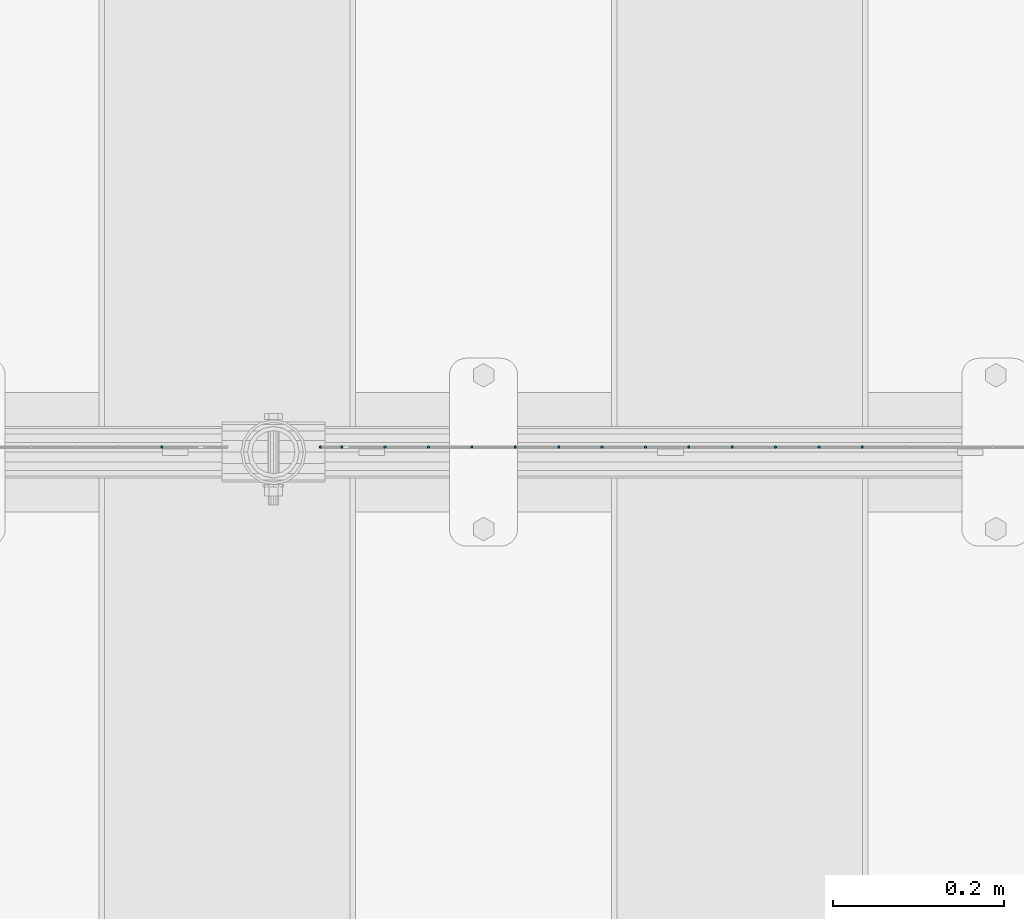
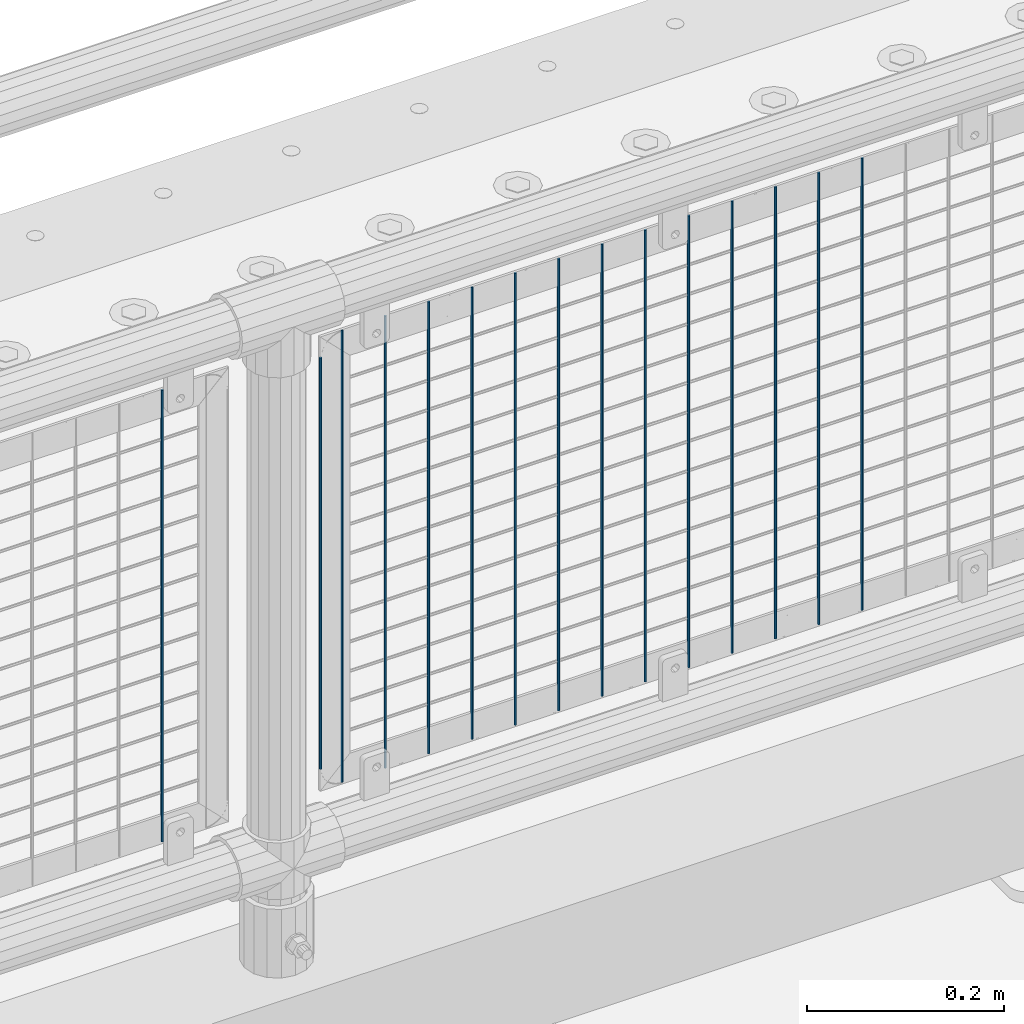
# One storey, part 71 of 270: 15 columns.
"""IFC2X3 building model written with IfcOpenShell, lengths in millimetres."""

import ifcopenshell
import ifcopenshell.guid

model = None  # the IFC model being written
_history = None  # IfcOwnerHistory: only IFC2X3 demands one
_inside = {}  # id of a spatial element -> (the spatial element, [elements in it])
_under = {}  # id of a project, library or spatial element -> (it, [spatial elements below it])
_declared = {}  # id of a project -> (the project, [libraries it declares])
_typed = {}  # id of a type object -> (the type object, [elements of that type])
_made_of = {}  # id of a material, layer set ... -> (it, [elements and type objects made of it])


def new_model(schema):
    """Start an empty IFC model of exactly this schema.

    Asked for "IFC4X3", IfcOpenShell would pick the latest addendum, in which some entities
    have other attributes; the version numbers below select the first issue.
    IFC2X3 requires an IfcOwnerHistory on every rooted entity: one is made here for all.
    """
    global model, _history
    if schema == "IFC4X3":
        model = ifcopenshell.file(schema_version=(4, 3, 0, 0))
    else:
        model = ifcopenshell.file(schema=schema)
    _inside.clear()
    _under.clear()
    _declared.clear()
    _typed.clear()
    _made_of.clear()
    _history = None
    if model.schema == "IFC2X3":
        org = make("IfcOrganization", Name="unknown")
        user = make(
            "IfcPersonAndOrganization",
            ThePerson=make("IfcPerson", FamilyName="unknown"),
            TheOrganization=org,
        )
        app = make(
            "IfcApplication",
            ApplicationDeveloper=org,
            Version="unknown",
            ApplicationFullName="unknown",
            ApplicationIdentifier="unknown",
        )
        _history = make(
            "IfcOwnerHistory",
            OwningUser=user,
            OwningApplication=app,
            ChangeAction="ADDED",
            CreationDate=0,
        )
    return model


def make(cls, **values):
    """One entity of the class cls with the attributes given. An attribute that is None is left unset."""
    return model.create_entity(
        cls, **{name: value for name, value in values.items() if value is not None}
    )


def rooted(cls, **values):
    """An entity with a GlobalId (a new one), such as an element, a storey or a relation."""
    return make(cls, GlobalId=ifcopenshell.guid.new(), OwnerHistory=_history, **values)


def si_unit(unit_type, name, prefix=None):
    """IfcSIUnit, for example si_unit("LENGTHUNIT", "METRE", prefix="MILLI")."""
    return make("IfcSIUnit", UnitType=unit_type, Prefix=prefix, Name=name)


def assignment(units):
    """IfcUnitAssignment: the units of a project."""
    return None if units is None else make("IfcUnitAssignment", Units=units)


def point(xyz):
    """IfcCartesianPoint."""
    return None if xyz is None else make("IfcCartesianPoint", Coordinates=xyz)


def direction(xyz):
    """IfcDirection."""
    return None if xyz is None else make("IfcDirection", DirectionRatios=xyz)


def frame(location, z_axis=None, x_axis=None):
    """IfcAxis2Placement3D, a coordinate frame: its origin and axes. An axis left out is left unset."""
    return make(
        "IfcAxis2Placement3D",
        Location=point(location),
        Axis=direction(z_axis),
        RefDirection=direction(x_axis),
    )


def origin_with_axes():
    """The frame at (0, 0, 0) with the z axis (0, 0, 1) and the x axis (1, 0, 0) written out."""
    return frame((0.0, 0.0, 0.0), z_axis=(0.0, 0.0, 1.0), x_axis=(1.0, 0.0, 0.0))


def place(relative_to, where):
    """IfcLocalPlacement: puts the frame where relative to a parent placement (None: the world)."""
    return make(
        "IfcLocalPlacement", PlacementRelTo=relative_to, RelativePlacement=where
    )


def context(
    kind, dimensions, precision=None, world=None, true_north=None, identifier=None
):
    """IfcGeometricRepresentationContext, for example the 3D "Model" context."""
    return make(
        "IfcGeometricRepresentationContext",
        ContextIdentifier=identifier,
        ContextType=kind,
        CoordinateSpaceDimension=dimensions,
        Precision=precision,
        WorldCoordinateSystem=world,
        TrueNorth=true_north,
    )


def subcontext(parent, identifier, kind, view, scale=None):
    """IfcGeometricRepresentationSubContext, for example "Body" below "Model"."""
    return make(
        "IfcGeometricRepresentationSubContext",
        ContextIdentifier=identifier,
        ContextType=kind,
        ParentContext=parent,
        TargetScale=scale,
        TargetView=view,
    )


def project(units=None, contexts=None):
    """IfcProject with its units and contexts."""
    return rooted(
        "IfcProject",
        Name="project",
        RepresentationContexts=contexts,
        UnitsInContext=assignment(units),
    )


def spatial(cls, under=None, at=None, **own):
    """A site, building, storey or space (cls), placed at a placement, below another one or the project."""
    s = rooted(cls, ObjectPlacement=at, **own)
    if under is not None:
        _under.setdefault(under.id(), (under, []))[1].append(s)
    return s


def faces_of(points, faces, orient=None, outer=None):
    """IfcFace entities. A face is a list of loops; a loop is a list of indices into points, from 0.

    orient and outer hold one flag for each loop. By default every Orientation is true, the
    first loop of a face is its IfcFaceOuterBound and the others are IfcFaceBound.
    """
    made = []
    for i, loops in enumerate(faces):
        bounds = []
        for j, loop in enumerate(loops):
            is_outer = j == 0 if outer is None else outer[i][j]
            bounds.append(
                make(
                    "IfcFaceOuterBound" if is_outer else "IfcFaceBound",
                    Bound=make("IfcPolyLoop", Polygon=[points[k] for k in loop]),
                    Orientation=True if orient is None else orient[i][j],
                )
            )
        made.append(make("IfcFace", Bounds=bounds))
    return made


def faceted_brep(points, faces, orient=None, outer=None, voids=None):
    """IfcFacetedBrep: a solid bounded by flat faces; with voids (closed shells), ...WithVoids."""
    shared = [point(p) for p in points]
    hull = make("IfcClosedShell", CfsFaces=faces_of(shared, faces, orient, outer))
    if voids is None:
        return make("IfcFacetedBrep", Outer=hull)
    return make(
        "IfcFacetedBrepWithVoids",
        Outer=hull,
        Voids=[
            make(cls, CfsFaces=faces_of(shared, fs, o, b)) for cls, fs, o, b in voids
        ],
    )


def shape(context_of_items, identifier, shape_type, items):
    """IfcShapeRepresentation: the items that make up one representation, for example the "Body"."""
    return make(
        "IfcShapeRepresentation",
        ContextOfItems=context_of_items,
        RepresentationIdentifier=identifier,
        RepresentationType=shape_type,
        Items=items,
    )


def material(Name=None, Category=None):
    """IfcMaterial."""
    return make("IfcMaterial", Name=Name, Category=Category)


def made_of(thing, what):
    """Note that an element or type object is made of a material, layer set ...; save() writes the relation."""
    if what is not None:
        _made_of.setdefault(what.id(), (what, []))[1].append(thing)
    return thing


def type_object(cls, material=None, **own):
    """A type object (cls), such as IfcWallType, which elements share."""
    return made_of(rooted(cls, **own), material)


def element(
    cls,
    number,
    at=None,
    inside=None,
    cuts=None,
    type_object=None,
    material=None,
    context=None,
    identifier="Body",
    shape_type=None,
    held_by="IfcProductDefinitionShape",
    body=None,
    shapes=None,
    **own,
):
    """One element of the class cls, such as IfcWall. Its Tag is "e" and its number.

    at: its placement. inside: the storey or other place that contains it. cuts: it is an
    opening in that element (IfcRelVoidsElement). A single representation is given by context,
    identifier, shape_type and body (its items); several are given by shapes. held_by: the class
    of the entity that holds the representations. save() writes the other relations.
    """
    e = rooted(cls, Tag="e%d" % number, ObjectPlacement=at, **own)
    if body is not None:
        shapes = [shape(context, identifier, shape_type, body)]
    if shapes is not None:
        e.Representation = make(held_by, Representations=shapes)
    if inside is not None:
        _inside.setdefault(inside.id(), (inside, []))[1].append(e)
    if cuts is not None:
        rooted(
            "IfcRelVoidsElement", RelatingBuildingElement=cuts, RelatedOpeningElement=e
        )
    if type_object is not None:
        _typed.setdefault(type_object.id(), (type_object, []))[1].append(e)
    return made_of(e, material)


def aggregate(whole, parts):
    """IfcRelAggregates: a whole, such as a stair, and the parts it consists of."""
    return rooted("IfcRelAggregates", RelatingObject=whole, RelatedObjects=parts)


def save(model, path):
    """Write the relations noted so far, then the file.

    IfcRelAggregates (storeys below a building ...), IfcRelContainedInSpatialStructure (elements
    in a storey), IfcRelDefinesByType, IfcRelAssociatesMaterial and IfcRelDeclares: one each for
    every whole, place, type object, material and project.
    """
    for whole, parts in _under.values():
        aggregate(whole, parts)
    for where, things in _inside.values():
        rooted(
            "IfcRelContainedInSpatialStructure",
            RelatedElements=things,
            RelatingStructure=where,
        )
    for kind, things in _typed.values():
        rooted("IfcRelDefinesByType", RelatedObjects=things, RelatingType=kind)
    for what, things in _made_of.values():
        rooted("IfcRelAssociatesMaterial", RelatedObjects=things, RelatingMaterial=what)
    for by, libraries in _declared.values():
        rooted("IfcRelDeclares", RelatingContext=by, RelatedDefinitions=libraries)
    model.write(path)


model = new_model("IFC2X3")

# Units and contexts
model_context = context("Model", 3, precision=1e-05, world=origin_with_axes())
body_context = subcontext(model_context, "Body", "Model", "MODEL_VIEW")
ifc_project = project(units=[si_unit("LENGTHUNIT", "METRE", prefix="MILLI"), si_unit("AREAUNIT", "SQUARE_METRE"), si_unit("VOLUMEUNIT", "CUBIC_METRE"), si_unit("MASSUNIT", "GRAM", prefix="KILO"), si_unit("TIMEUNIT", "SECOND"), si_unit("PLANEANGLEUNIT", "RADIAN"), si_unit("SOLIDANGLEUNIT", "STERADIAN"), si_unit("THERMODYNAMICTEMPERATUREUNIT", "DEGREE_CELSIUS"), si_unit("LUMINOUSINTENSITYUNIT", "LUMEN")], contexts=[model_context])

# Site, building, storey
site_placement = place(None, origin_with_axes())
site = spatial("IfcSite", under=ifc_project, at=site_placement, CompositionType="ELEMENT")
building_placement = place(site_placement, origin_with_axes())
building = spatial("IfcBuilding", under=site, at=building_placement, Name="Standard", CompositionType="ELEMENT")
storey_placement = place(building_placement, origin_with_axes())
storey = spatial("IfcBuildingStorey", under=building, at=storey_placement, Name="Undefined", CompositionType="ELEMENT", Elevation=0.0)

# Columns
ifc_material = material(Name="Misc_Undefined")
column_type = type_object("IfcColumnType", Name="D3", PredefinedType="NOTDEFINED")
for number, where, z_axis, x_axis in (
    (1, (2943.516, -16329.5, 353.02), (-1.0, 0.0, 0.0), (0.0, 0.0, 1.0)),
    (2, (2892.723, -16329.5, 353.02), (-1.0, 0.0, 0.0), (0.0, 0.0, 1.0)),
    (3, (2841.93, -16329.5, 353.02), (-1.0, 0.0, 0.0), (0.0, 0.0, 1.0)),
    (4, (2791.137, -16329.5, 353.02), (-1.0, 0.0, 0.0), (0.0, 0.0, 1.0)),
    (5, (2740.344, -16329.5, 353.02), (-1.0, 0.0, 0.0), (0.0, 0.0, 1.0)),
    (6, (2689.551, -16329.5, 353.02), (-1.0, 0.0, 0.0), (0.0, 0.0, 1.0)),
    (7, (2638.758, -16329.5, 353.02), (-1.0, 0.0, 0.0), (0.0, 0.0, 1.0)),
    (8, (2587.965, -16329.5, 353.02), (-1.0, 0.0, 0.0), (0.0, 0.0, 1.0)),
    (9, (2537.172, -16329.5, 353.02), (-1.0, 0.0, 0.0), (0.0, 0.0, 1.0)),
    (10, (2486.379, -16329.5, 353.02), (-1.0, 0.0, 0.0), (0.0, 0.0, 1.0)),
    (11, (2435.586, -16329.5, 353.02), (-1.0, 0.0, 0.0), (0.0, 0.0, 1.0)),
    (12, (2384.793, -16329.5, 353.02), (-1.0, 0.0, 0.0), (0.0, 0.0, 1.0)),
):
    element("IfcColumn", number, at=place(storey_placement, frame(where, z_axis=z_axis, x_axis=x_axis)), inside=storey, type_object=column_type, material=ifc_material, ObjectType="D3", context=body_context, shape_type="Brep", body=[
        faceted_brep([(0.0, -1.5, 0.0), (0.0, -0.75, -1.29903810567669), (560.0, -0.75, -1.29903810567703), (560.0, -1.5, 0.0), (0.0, 0.75, -1.29903810567669), (560.0, 0.75, -1.29903810567703), (0.0, 1.5, 0.0), (560.0, 1.5, 0.0), (0.0, 0.75, 1.29903810567669), (560.0, 0.75, 1.29903810567703), (0.0, -0.75, 1.29903810567669), (560.0, -0.75, 1.29903810567703)], [[[0, 1, 2, 3]], [[1, 4, 5, 2]], [[4, 6, 7, 5]], [[6, 8, 9, 7]], [[8, 10, 11, 9]], [[10, 0, 3, 11]], [[5, 7, 9, 11, 3, 2]], [[10, 8, 6, 4, 1, 0]]]),
    ])
column_placement = place(storey_placement, frame((2309.0, -16329.5, 378.02), z_axis=(-1.0, 0.0, 0.0), x_axis=(0.0, 0.0, 1.0)))
element("IfcColumn", 13, at=column_placement, inside=storey, type_object=column_type, material=ifc_material, ObjectType="D3", context=body_context, shape_type="Brep", body=[
    faceted_brep([(0.0, -1.5, 0.0), (0.0, -0.75, -1.29903810567669), (510.0, -0.75, -1.29903810567703), (510.0, -1.5, 0.0), (0.0, 0.75, -1.29903810567669), (510.0, 0.75, -1.29903810567703), (0.0, 1.5, 0.0), (510.0, 1.5, 0.0), (0.0, 0.75, 1.29903810567669), (510.0, 0.75, 1.29903810567703), (0.0, -0.75, 1.29903810567669), (510.0, -0.75, 1.29903810567703)], [[[0, 1, 2, 3]], [[1, 4, 5, 2]], [[4, 6, 7, 5]], [[6, 8, 9, 7]], [[8, 10, 11, 9]], [[10, 0, 3, 11]], [[5, 7, 9, 11, 3, 2]], [[10, 8, 6, 4, 1, 0]]]),
])
for number, where, z_axis, x_axis in (
    (14, (2334.0, -16329.5, 353.02), (-1.0, 0.0, 0.0), (0.0, 0.0, 1.0)),
    (15, (2123.204, -16329.5, 353.02), (-1.0, 0.0, 0.0), (0.0, 0.0, 1.0)),
):
    element("IfcColumn", number, at=place(storey_placement, frame(where, z_axis=z_axis, x_axis=x_axis)), inside=storey, type_object=column_type, material=ifc_material, ObjectType="D3", context=body_context, shape_type="Brep", body=[
        faceted_brep([(0.0, -1.5, 0.0), (0.0, -0.75, -1.29903810567669), (560.0, -0.75, -1.29903810567703), (560.0, -1.5, 0.0), (0.0, 0.75, -1.29903810567669), (560.0, 0.75, -1.29903810567703), (0.0, 1.5, 0.0), (560.0, 1.5, 0.0), (0.0, 0.75, 1.29903810567669), (560.0, 0.75, 1.29903810567703), (0.0, -0.75, 1.29903810567669), (560.0, -0.75, 1.29903810567703)], [[[0, 1, 2, 3]], [[1, 4, 5, 2]], [[4, 6, 7, 5]], [[6, 8, 9, 7]], [[8, 10, 11, 9]], [[10, 0, 3, 11]], [[5, 7, 9, 11, 3, 2]], [[10, 8, 6, 4, 1, 0]]]),
    ])

save(model, "model.ifc")
